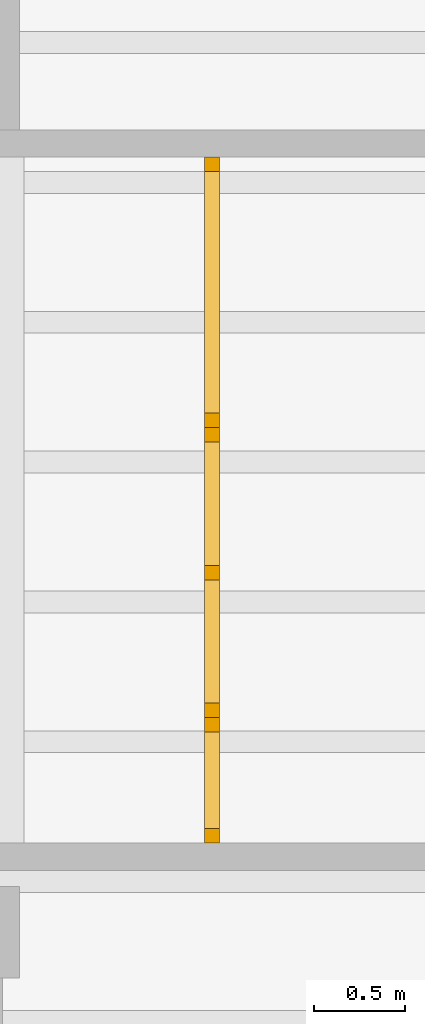
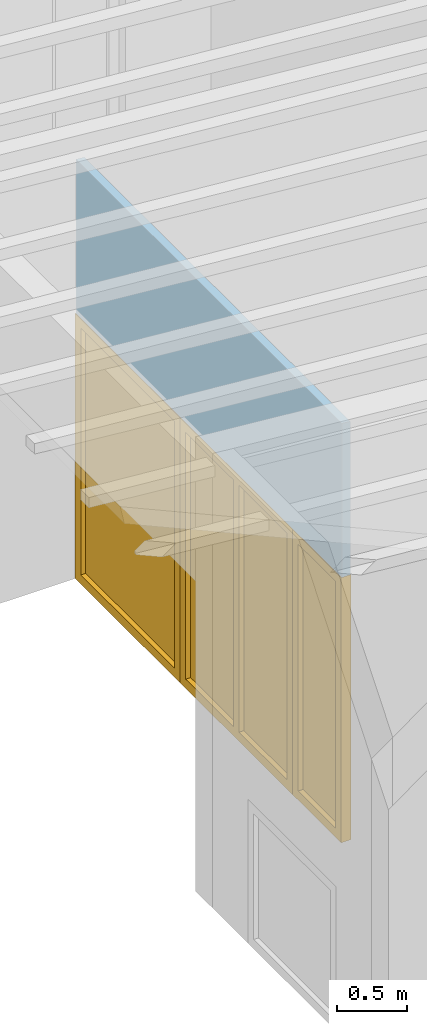
# One storey, part 8 of 13: 2 doors, 1 window, 3 openings, plus 1 element that does not belong to this part.
"""IFC2X3 building model written with IfcOpenShell, lengths in millimetres."""

from ifc_helpers import new_model, entity, si_unit, converted_unit, frame, frame_2d, origin, origin_with_axes, place, context, project, spatial, rectangle, extrude, clip, halfspace, faceted_brep, material, layer, layer_set, layer_usage, type_object, element, fill, save


model = new_model("IFC2X3")

# Units and contexts
model_context = context("Model", 3, precision=1e-05, world=origin())
plan_context = context("Plan", 3, precision=1e-05, world=origin())
ifc_project = project(units=[si_unit("LENGTHUNIT", "METRE", prefix="MILLI"), converted_unit("PLANEANGLEUNIT", "DEGREE", entity("IfcPlaneAngleMeasure", 0.0174532925199433), si_unit("PLANEANGLEUNIT", "RADIAN"), dimensions=[0, 0, 0, 0, 0, 0, 0]), si_unit("AREAUNIT", "SQUARE_METRE"), si_unit("VOLUMEUNIT", "CUBIC_METRE")], contexts=[model_context, plan_context])

# Building, storey
building_placement = place(None, origin())
building = spatial("IfcBuilding", under=ifc_project, at=building_placement, CompositionType="ELEMENT")
storey_placement = place(building_placement, frame((0.0, 0.0, 4770.0), z_axis=(0.0, 0.0, 1.0), x_axis=(1.0, 0.0, 0.0)))
storey = spatial("IfcBuildingStorey", under=building, at=storey_placement, Name="Geschoss", CompositionType="ELEMENT", Elevation=4770.0)

# Wall, openings, doors, window
ifc_material_1 = material(Name="glas")
ifc_layer = layer(ifc_material_1, 70.0)
ifc_layer_set = layer_set([ifc_layer])
ifc_layer_usage = layer_usage(ifc_layer_set, "AXIS2", "POSITIVE", 0.0)
wall_placement = place(storey_placement, frame((22458.3517822139, 1928.4375, 0.0), z_axis=(0.0, 0.0, 1.0), x_axis=(0.0, 1.0, 0.0)))
wall = element("IfcWallStandardCase", 1, at=wall_placement, inside=storey, material=ifc_layer_usage, context=model_context, shape_type="Clipping", body=[
    clip(extrude(rectangle(XDim=3780.0, YDim=70.0, at=frame_2d((1890.0, 35.0), x_axis=(1.0, 0.0))), origin_with_axes(), (0.0, 0.0, 1.0), 3635.62189784294), halfspace(frame((0.0, 0.0, 3629.49769139612), z_axis=(0.0, 0.0871557427476649, -0.996194698091745), x_axis=(1.0, 0.0, 0.0)), True)),
])
opening_1_placement = place(wall_placement, frame((0.0, 0.0, 0.0), z_axis=(0.0, 1.0, 0.0), x_axis=(0.0, 0.0, 1.0)))
opening_1 = element("IfcOpeningElement", 2, at=opening_1_placement, cuts=wall, ObjectType="Opening", context=model_context, shape_type="SweptSolid", body=[
    extrude(rectangle(XDim=2300.0, YDim=689.999999999996, at=frame_2d((1150.0, 344.999999999998), x_axis=(1.0, 0.0))), origin_with_axes(), (0.0, 0.0, 1.0), 70.0),
])
opening_2_placement = place(wall_placement, frame((2290.0, 0.0, 0.0), z_axis=(0.0, 1.0, 0.0), x_axis=(0.0, 0.0, 1.0)))
opening_2 = element("IfcOpeningElement", 3, at=opening_2_placement, cuts=wall, ObjectType="Opening", context=model_context, shape_type="SweptSolid", body=[
    extrude(rectangle(XDim=2300.0, YDim=1490.0, at=frame_2d((1150.0, 745.0), x_axis=(1.0, 0.0))), origin_with_axes(), (0.0, 0.0, 1.0), 70.0),
])
opening_3_placement = place(wall_placement, frame((689.999999999996, 0.0, 0.0), z_axis=(0.0, 1.0, 0.0), x_axis=(0.0, 0.0, 1.0)))
opening_3 = element("IfcOpeningElement", 4, at=opening_3_placement, cuts=wall, ObjectType="Opening", context=model_context, shape_type="SweptSolid", body=[
    extrude(rectangle(XDim=2300.0, YDim=1600.0, at=frame_2d((1150.0, 800.0), x_axis=(1.0, 0.0))), origin_with_axes(), (0.0, 0.0, 1.0), 70.0),
])
ifc_material_2 = material()
door_style_1 = type_object("IfcDoorStyle", Name="Verglasung 01", ConstructionType="NOTDEFINED", OperationType="USERDEFINED", ParameterTakesPrecedence=False, Sizeable=False)
door_1_placement = place(opening_1_placement, frame((0.0, 0.0, 0.0), z_axis=(1.0, 0.0, 0.0), x_axis=(0.0, 1.0, 0.0)))
door_1 = element("IfcDoor", 5, at=door_1_placement, inside=storey, type_object=door_style_1, material=ifc_material_2, Name="Verglasung 01", OverallHeight=2300.0, OverallWidth=690.0, context=model_context, shape_type="Brep", body=[
    faceted_brep([(80.0, 75.0000000000015, 0.0), (80.0, 75.0000000000015, 2300.0), (0.0, 75.0000000000015, 2300.0), (0.0, 75.0000000000015, 0.0), (0.0, -4.99999999999849, 0.0), (0.0, -4.99999999999849, 2300.0), (80.0, -4.99999999999849, 2300.0), (80.0, -4.99999999999849, 0.0), (0.0, 75.0000000000015, 0.0), (0.0, -4.99999999999849, 0.0), (80.0, -4.99999999999849, 0.0), (80.0, 75.0000000000015, 0.0), (0.0, 75.0000000000015, 2300.0), (0.0, -4.99999999999849, 2300.0), (0.0, -4.99999999999849, 0.0), (0.0, 75.0000000000015, 0.0), (80.0, 75.0000000000015, 2300.0), (80.0, -4.99999999999849, 2300.0), (0.0, -4.99999999999849, 2300.0), (0.0, 75.0000000000015, 2300.0), (80.0, 75.0000000000015, 0.0), (80.0, -4.99999999999849, 0.0), (80.0, -4.99999999999849, 2300.0), (80.0, 75.0000000000015, 2300.0)], [[[0, 1, 2, 3]], [[4, 5, 6, 7]], [[8, 9, 10, 11]], [[12, 13, 14, 15]], [[16, 17, 18, 19]], [[20, 21, 22, 23]]], orient=[[False], [False], [False], [False], [False], [False]]),
    faceted_brep([(609.999999999996, 75.0000000000015, 2300.0), (609.999999999996, 75.0000000000015, 0.0), (689.999999999996, 75.0000000000015, 0.0), (689.999999999996, 75.0000000000015, 2300.0), (689.999999999996, -4.99999999999854, 2300.0), (689.999999999996, -4.99999999999854, 0.0), (609.999999999996, -4.99999999999854, 0.0), (609.999999999996, -4.99999999999854, 2300.0), (689.999999999996, 75.0000000000015, 2300.0), (689.999999999996, -4.99999999999854, 2300.0), (609.999999999996, -4.99999999999854, 2300.0), (609.999999999996, 75.0000000000015, 2300.0), (689.999999999996, 75.0000000000015, 0.0), (689.999999999996, -4.99999999999854, 0.0), (689.999999999996, -4.99999999999854, 2300.0), (689.999999999996, 75.0000000000015, 2300.0), (609.999999999996, 75.0000000000015, 0.0), (609.999999999996, -4.99999999999854, 0.0), (689.999999999996, -4.99999999999854, 0.0), (689.999999999996, 75.0000000000015, 0.0), (609.999999999996, 75.0000000000015, 2300.0), (609.999999999996, -4.99999999999854, 2300.0), (609.999999999996, -4.99999999999854, 0.0), (609.999999999996, 75.0000000000015, 0.0)], [[[0, 1, 2, 3]], [[4, 5, 6, 7]], [[8, 9, 10, 11]], [[12, 13, 14, 15]], [[16, 17, 18, 19]], [[20, 21, 22, 23]]], orient=[[False], [False], [False], [False], [False], [False]]),
    faceted_brep([(80.0, 75.0000000000015, 2220.0), (609.999999999996, 75.0000000000015, 2220.0), (609.999999999996, 75.0000000000015, 2300.0), (80.0, 75.0000000000015, 2300.0), (80.0, -4.99999999999851, 2300.0), (609.999999999996, -4.99999999999855, 2300.0), (609.999999999996, -4.99999999999855, 2220.0), (80.0, -4.99999999999851, 2220.0), (80.0, 75.0000000000015, 2300.0), (80.0, -4.99999999999851, 2300.0), (80.0, -4.99999999999851, 2220.0), (80.0, 75.0000000000015, 2220.0), (609.999999999996, 75.0000000000015, 2300.0), (609.999999999996, -4.99999999999855, 2300.0), (80.0, -4.99999999999851, 2300.0), (80.0, 75.0000000000015, 2300.0), (609.999999999996, 75.0000000000015, 2220.0), (609.999999999996, -4.99999999999855, 2220.0), (609.999999999996, -4.99999999999855, 2300.0), (609.999999999996, 75.0000000000015, 2300.0), (80.0, 75.0000000000015, 2220.0), (80.0, -4.99999999999851, 2220.0), (609.999999999996, -4.99999999999855, 2220.0), (609.999999999996, 75.0000000000015, 2220.0)], [[[0, 1, 2, 3]], [[4, 5, 6, 7]], [[8, 9, 10, 11]], [[12, 13, 14, 15]], [[16, 17, 18, 19]], [[20, 21, 22, 23]]], orient=[[False], [False], [False], [False], [False], [False]]),
    faceted_brep([(609.999999999996, 75.0000000000015, 80.0), (80.0, 75.0000000000015, 80.0), (80.0, 75.0000000000015, 0.0), (609.999999999996, 75.0000000000015, 0.0), (609.999999999996, -4.99999999999855, 0.0), (80.0, -4.99999999999851, 0.0), (80.0, -4.99999999999851, 80.0), (609.999999999996, -4.99999999999855, 80.0), (609.999999999996, 75.0000000000015, 0.0), (609.999999999996, -4.99999999999855, 0.0), (609.999999999996, -4.99999999999855, 80.0), (609.999999999996, 75.0000000000015, 80.0), (80.0, 75.0000000000015, 0.0), (80.0, -4.99999999999851, 0.0), (609.999999999996, -4.99999999999855, 0.0), (609.999999999996, 75.0000000000015, 0.0), (80.0, 75.0000000000015, 80.0), (80.0, -4.99999999999851, 80.0), (80.0, -4.99999999999851, 0.0), (80.0, 75.0000000000015, 0.0), (609.999999999996, 75.0000000000015, 80.0), (609.999999999996, -4.99999999999855, 80.0), (80.0, -4.99999999999851, 80.0), (80.0, 75.0000000000015, 80.0)], [[[0, 1, 2, 3]], [[4, 5, 6, 7]], [[8, 9, 10, 11]], [[12, 13, 14, 15]], [[16, 17, 18, 19]], [[20, 21, 22, 23]]], orient=[[False], [False], [False], [False], [False], [False]]),
    faceted_brep([(80.0, 35.0000000000015, 80.0), (609.999999999996, 35.0000000000015, 80.0), (609.999999999996, 35.0000000000015, 2220.0), (80.0, 35.0000000000015, 2220.0), (80.0, 34.0000000000015, 80.0), (80.0, 34.0000000000015, 2220.0), (609.999999999996, 34.0000000000015, 2220.0), (609.999999999996, 34.0000000000015, 80.0), (80.0, 35.0000000000015, 80.0), (80.0, 34.0000000000015, 80.0), (609.999999999996, 34.0000000000015, 80.0), (609.999999999996, 35.0000000000015, 80.0), (609.999999999996, 35.0000000000015, 80.0), (609.999999999996, 34.0000000000015, 80.0), (609.999999999996, 34.0000000000015, 2220.0), (609.999999999996, 35.0000000000015, 2220.0), (609.999999999996, 35.0000000000015, 2220.0), (609.999999999996, 34.0000000000015, 2220.0), (80.0, 34.0000000000015, 2220.0), (80.0, 35.0000000000015, 2220.0), (80.0, 35.0000000000015, 2220.0), (80.0, 34.0000000000015, 2220.0), (80.0, 34.0000000000015, 80.0), (80.0, 35.0000000000015, 80.0)], [[[0, 1, 2, 3]], [[4, 5, 6, 7]], [[8, 9, 10, 11]], [[12, 13, 14, 15]], [[16, 17, 18, 19]], [[20, 21, 22, 23]]], orient=[[False], [False], [False], [False], [False], [False]]),
])
fill(opening_1, door_1)
ifc_material_3 = material()
door_style_2 = type_object("IfcDoorStyle", Name="m", ConstructionType="NOTDEFINED", OperationType="USERDEFINED", ParameterTakesPrecedence=False, Sizeable=False)
door_2_placement = place(opening_2_placement, frame((0.0, 0.0, 0.0), z_axis=(1.0, 0.0, 0.0), x_axis=(0.0, 1.0, 0.0)))
door_2 = element("IfcDoor", 6, at=door_2_placement, inside=storey, type_object=door_style_2, material=ifc_material_3, Name="m", OverallHeight=2300.0, OverallWidth=1490.0, context=model_context, shape_type="Brep", body=[
    faceted_brep([(79.9999999999998, 75.0000000000016, 0.0), (79.9999999999998, 75.0000000000016, 2300.0), (-2.27373675443232e-13, 75.0000000000016, 2300.0), (-2.27373675443232e-13, 75.0000000000016, 0.0), (-2.27373675443232e-13, -4.99999999999845, 0.0), (-2.27373675443232e-13, -4.99999999999845, 2300.0), (79.9999999999998, -4.99999999999845, 2300.0), (79.9999999999998, -4.99999999999845, 0.0), (-2.27373675443232e-13, 75.0000000000016, 0.0), (-2.27373675443232e-13, -4.99999999999845, 0.0), (79.9999999999998, -4.99999999999845, 0.0), (79.9999999999998, 75.0000000000016, 0.0), (-2.27373675443232e-13, 75.0000000000016, 2300.0), (-2.27373675443232e-13, -4.99999999999845, 2300.0), (-2.27373675443232e-13, -4.99999999999845, 0.0), (-2.27373675443232e-13, 75.0000000000016, 0.0), (79.9999999999998, 75.0000000000016, 2300.0), (79.9999999999998, -4.99999999999845, 2300.0), (-2.27373675443232e-13, -4.99999999999845, 2300.0), (-2.27373675443232e-13, 75.0000000000016, 2300.0), (79.9999999999998, 75.0000000000016, 0.0), (79.9999999999998, -4.99999999999845, 0.0), (79.9999999999998, -4.99999999999845, 2300.0), (79.9999999999998, 75.0000000000016, 2300.0)], [[[0, 1, 2, 3]], [[4, 5, 6, 7]], [[8, 9, 10, 11]], [[12, 13, 14, 15]], [[16, 17, 18, 19]], [[20, 21, 22, 23]]], orient=[[False], [False], [False], [False], [False], [False]]),
    faceted_brep([(1410.0, 75.0000000000015, 2300.0), (1410.0, 75.0000000000015, 0.0), (1490.0, 75.0000000000015, 0.0), (1490.0, 75.0000000000015, 2300.0), (1490.0, -4.99999999999854, 2300.0), (1490.0, -4.99999999999854, 0.0), (1410.0, -4.99999999999854, 0.0), (1410.0, -4.99999999999854, 2300.0), (1490.0, 75.0000000000015, 2300.0), (1490.0, -4.99999999999854, 2300.0), (1410.0, -4.99999999999854, 2300.0), (1410.0, 75.0000000000015, 2300.0), (1490.0, 75.0000000000015, 0.0), (1490.0, -4.99999999999854, 0.0), (1490.0, -4.99999999999854, 2300.0), (1490.0, 75.0000000000015, 2300.0), (1410.0, 75.0000000000015, 0.0), (1410.0, -4.99999999999854, 0.0), (1490.0, -4.99999999999854, 0.0), (1490.0, 75.0000000000015, 0.0), (1410.0, 75.0000000000015, 2300.0), (1410.0, -4.99999999999854, 2300.0), (1410.0, -4.99999999999854, 0.0), (1410.0, 75.0000000000015, 0.0)], [[[0, 1, 2, 3]], [[4, 5, 6, 7]], [[8, 9, 10, 11]], [[12, 13, 14, 15]], [[16, 17, 18, 19]], [[20, 21, 22, 23]]], orient=[[False], [False], [False], [False], [False], [False]]),
    faceted_brep([(79.9999999999998, 75.0000000000015, 2220.0), (1410.0, 75.0000000000015, 2220.0), (1410.0, 75.0000000000015, 2300.0), (79.9999999999998, 75.0000000000015, 2300.0), (79.9999999999998, -4.99999999999847, 2300.0), (1410.0, -4.99999999999855, 2300.0), (1410.0, -4.99999999999855, 2220.0), (79.9999999999998, -4.99999999999847, 2220.0), (79.9999999999998, 75.0000000000015, 2300.0), (79.9999999999998, -4.99999999999847, 2300.0), (79.9999999999998, -4.99999999999847, 2220.0), (79.9999999999998, 75.0000000000015, 2220.0), (1410.0, 75.0000000000015, 2300.0), (1410.0, -4.99999999999855, 2300.0), (79.9999999999998, -4.99999999999847, 2300.0), (79.9999999999998, 75.0000000000015, 2300.0), (1410.0, 75.0000000000015, 2220.0), (1410.0, -4.99999999999855, 2220.0), (1410.0, -4.99999999999855, 2300.0), (1410.0, 75.0000000000015, 2300.0), (79.9999999999998, 75.0000000000015, 2220.0), (79.9999999999998, -4.99999999999847, 2220.0), (1410.0, -4.99999999999855, 2220.0), (1410.0, 75.0000000000015, 2220.0)], [[[0, 1, 2, 3]], [[4, 5, 6, 7]], [[8, 9, 10, 11]], [[12, 13, 14, 15]], [[16, 17, 18, 19]], [[20, 21, 22, 23]]], orient=[[False], [False], [False], [False], [False], [False]]),
    faceted_brep([(1410.0, 75.0000000000015, 80.0), (79.9999999999998, 75.0000000000015, 80.0), (79.9999999999998, 75.0000000000015, 0.0), (1410.0, 75.0000000000015, 0.0), (1410.0, -4.99999999999855, 0.0), (79.9999999999998, -4.99999999999847, 0.0), (79.9999999999998, -4.99999999999847, 80.0), (1410.0, -4.99999999999855, 80.0), (1410.0, 75.0000000000015, 0.0), (1410.0, -4.99999999999855, 0.0), (1410.0, -4.99999999999855, 80.0), (1410.0, 75.0000000000015, 80.0), (79.9999999999998, 75.0000000000015, 0.0), (79.9999999999998, -4.99999999999847, 0.0), (1410.0, -4.99999999999855, 0.0), (1410.0, 75.0000000000015, 0.0), (79.9999999999998, 75.0000000000015, 80.0), (79.9999999999998, -4.99999999999847, 80.0), (79.9999999999998, -4.99999999999847, 0.0), (79.9999999999998, 75.0000000000015, 0.0), (1410.0, 75.0000000000015, 80.0), (1410.0, -4.99999999999855, 80.0), (79.9999999999998, -4.99999999999847, 80.0), (79.9999999999998, 75.0000000000015, 80.0)], [[[0, 1, 2, 3]], [[4, 5, 6, 7]], [[8, 9, 10, 11]], [[12, 13, 14, 15]], [[16, 17, 18, 19]], [[20, 21, 22, 23]]], orient=[[False], [False], [False], [False], [False], [False]]),
    faceted_brep([(79.9999999999998, 35.0000000000015, 80.0), (1410.0, 35.0000000000015, 80.0), (1410.0, 35.0000000000015, 2220.0), (79.9999999999998, 35.0000000000015, 2220.0), (79.9999999999998, 34.0000000000015, 80.0), (79.9999999999998, 34.0000000000015, 2220.0), (1410.0, 34.0000000000015, 2220.0), (1410.0, 34.0000000000015, 80.0), (79.9999999999998, 35.0000000000015, 80.0), (79.9999999999998, 34.0000000000015, 80.0), (1410.0, 34.0000000000015, 80.0), (1410.0, 35.0000000000015, 80.0), (1410.0, 35.0000000000015, 80.0), (1410.0, 34.0000000000015, 80.0), (1410.0, 34.0000000000015, 2220.0), (1410.0, 35.0000000000015, 2220.0), (1410.0, 35.0000000000015, 2220.0), (1410.0, 34.0000000000015, 2220.0), (79.9999999999998, 34.0000000000015, 2220.0), (79.9999999999998, 35.0000000000015, 2220.0), (79.9999999999998, 35.0000000000015, 2220.0), (79.9999999999998, 34.0000000000015, 2220.0), (79.9999999999998, 34.0000000000015, 80.0), (79.9999999999998, 35.0000000000015, 80.0)], [[[0, 1, 2, 3]], [[4, 5, 6, 7]], [[8, 9, 10, 11]], [[12, 13, 14, 15]], [[16, 17, 18, 19]], [[20, 21, 22, 23]]], orient=[[False], [False], [False], [False], [False], [False]]),
])
fill(opening_2, door_2)
ifc_material_4 = material()
window_placement = place(opening_3_placement, frame((0.0, 0.0, 0.0), z_axis=(1.0, 0.0, 0.0), x_axis=(0.0, 1.0, 0.0)))
window = element("IfcWindow", 7, at=window_placement, inside=storey, material=ifc_material_4, Name="m", OverallHeight=2300.0, OverallWidth=1600.0, context=model_context, shape_type="Brep", body=[
    faceted_brep([(80.0000000000005, 75.0000000000016, 0.0), (80.0000000000005, 75.0000000000016, 2300.0), (4.54747350886464e-13, 75.0000000000016, 2300.0), (4.54747350886464e-13, 75.0000000000016, 0.0), (4.54747350886464e-13, -4.99999999999844, 0.0), (4.54747350886464e-13, -4.99999999999844, 2300.0), (80.0000000000005, -4.99999999999844, 2300.0), (80.0000000000005, -4.99999999999844, 0.0), (4.54747350886464e-13, 75.0000000000016, 0.0), (4.54747350886464e-13, -4.99999999999844, 0.0), (80.0000000000005, -4.99999999999844, 0.0), (80.0000000000005, 75.0000000000016, 0.0), (4.54747350886464e-13, 75.0000000000016, 2300.0), (4.54747350886464e-13, -4.99999999999844, 2300.0), (4.54747350886464e-13, -4.99999999999844, 0.0), (4.54747350886464e-13, 75.0000000000016, 0.0), (80.0000000000005, 75.0000000000016, 2300.0), (80.0000000000005, -4.99999999999844, 2300.0), (4.54747350886464e-13, -4.99999999999844, 2300.0), (4.54747350886464e-13, 75.0000000000016, 2300.0), (80.0000000000005, 75.0000000000016, 0.0), (80.0000000000005, -4.99999999999844, 0.0), (80.0000000000005, -4.99999999999844, 2300.0), (80.0000000000005, 75.0000000000016, 2300.0)], [[[0, 1, 2, 3]], [[4, 5, 6, 7]], [[8, 9, 10, 11]], [[12, 13, 14, 15]], [[16, 17, 18, 19]], [[20, 21, 22, 23]]], orient=[[False], [False], [False], [False], [False], [False]]),
    faceted_brep([(1520.0, 75.0000000000015, 2300.0), (1520.0, 75.0000000000015, 0.0), (1600.0, 75.0000000000015, 0.0), (1600.0, 75.0000000000015, 2300.0), (1600.0, -4.99999999999854, 2300.0), (1600.0, -4.99999999999854, 0.0), (1520.0, -4.99999999999854, 0.0), (1520.0, -4.99999999999854, 2300.0), (1600.0, 75.0000000000015, 2300.0), (1600.0, -4.99999999999854, 2300.0), (1520.0, -4.99999999999854, 2300.0), (1520.0, 75.0000000000015, 2300.0), (1600.0, 75.0000000000015, 0.0), (1600.0, -4.99999999999854, 0.0), (1600.0, -4.99999999999854, 2300.0), (1600.0, 75.0000000000015, 2300.0), (1520.0, 75.0000000000015, 0.0), (1520.0, -4.99999999999854, 0.0), (1600.0, -4.99999999999854, 0.0), (1600.0, 75.0000000000015, 0.0), (1520.0, 75.0000000000015, 2300.0), (1520.0, -4.99999999999854, 2300.0), (1520.0, -4.99999999999854, 0.0), (1520.0, 75.0000000000015, 0.0)], [[[0, 1, 2, 3]], [[4, 5, 6, 7]], [[8, 9, 10, 11]], [[12, 13, 14, 15]], [[16, 17, 18, 19]], [[20, 21, 22, 23]]], orient=[[False], [False], [False], [False], [False], [False]]),
    faceted_brep([(80.0000000000005, 75.0000000000015, 2220.0), (1520.0, 75.0000000000015, 2220.0), (1520.0, 75.0000000000015, 2300.0), (80.0000000000005, 75.0000000000015, 2300.0), (80.0000000000005, -4.99999999999845, 2300.0), (1520.0, -4.99999999999855, 2300.0), (1520.0, -4.99999999999855, 2220.0), (80.0000000000005, -4.99999999999845, 2220.0), (80.0000000000005, 75.0000000000015, 2300.0), (80.0000000000005, -4.99999999999845, 2300.0), (80.0000000000005, -4.99999999999845, 2220.0), (80.0000000000005, 75.0000000000015, 2220.0), (1520.0, 75.0000000000015, 2300.0), (1520.0, -4.99999999999855, 2300.0), (80.0000000000005, -4.99999999999845, 2300.0), (80.0000000000005, 75.0000000000015, 2300.0), (1520.0, 75.0000000000015, 2220.0), (1520.0, -4.99999999999855, 2220.0), (1520.0, -4.99999999999855, 2300.0), (1520.0, 75.0000000000015, 2300.0), (80.0000000000005, 75.0000000000015, 2220.0), (80.0000000000005, -4.99999999999845, 2220.0), (1520.0, -4.99999999999855, 2220.0), (1520.0, 75.0000000000015, 2220.0)], [[[0, 1, 2, 3]], [[4, 5, 6, 7]], [[8, 9, 10, 11]], [[12, 13, 14, 15]], [[16, 17, 18, 19]], [[20, 21, 22, 23]]], orient=[[False], [False], [False], [False], [False], [False]]),
    faceted_brep([(1520.0, 75.0000000000015, 80.0), (80.0000000000005, 75.0000000000015, 80.0), (80.0000000000005, 75.0000000000015, 0.0), (1520.0, 75.0000000000015, 0.0), (1520.0, -4.99999999999855, 0.0), (80.0000000000005, -4.99999999999845, 0.0), (80.0000000000005, -4.99999999999845, 80.0), (1520.0, -4.99999999999855, 80.0), (1520.0, 75.0000000000015, 0.0), (1520.0, -4.99999999999855, 0.0), (1520.0, -4.99999999999855, 80.0), (1520.0, 75.0000000000015, 80.0), (80.0000000000005, 75.0000000000015, 0.0), (80.0000000000005, -4.99999999999845, 0.0), (1520.0, -4.99999999999855, 0.0), (1520.0, 75.0000000000015, 0.0), (80.0000000000005, 75.0000000000015, 80.0), (80.0000000000005, -4.99999999999845, 80.0), (80.0000000000005, -4.99999999999845, 0.0), (80.0000000000005, 75.0000000000015, 0.0), (1520.0, 75.0000000000015, 80.0), (1520.0, -4.99999999999855, 80.0), (80.0000000000005, -4.99999999999845, 80.0), (80.0000000000005, 75.0000000000015, 80.0)], [[[0, 1, 2, 3]], [[4, 5, 6, 7]], [[8, 9, 10, 11]], [[12, 13, 14, 15]], [[16, 17, 18, 19]], [[20, 21, 22, 23]]], orient=[[False], [False], [False], [False], [False], [False]]),
    faceted_brep([(840.0, 75.0000000000015, 80.0), (840.0, 75.0000000000015, 2220.0), (760.0, 75.0000000000015, 2220.0), (760.0, 75.0000000000015, 80.0), (760.0, -4.99999999999849, 80.0), (760.0, -4.99999999999849, 2220.0), (840.0, -4.99999999999851, 2220.0), (840.0, -4.99999999999851, 80.0), (760.0, 75.0000000000015, 80.0), (760.0, -4.99999999999849, 80.0), (840.0, -4.99999999999851, 80.0), (840.0, 75.0000000000015, 80.0), (760.0, 75.0000000000015, 2220.0), (760.0, -4.99999999999849, 2220.0), (760.0, -4.99999999999849, 80.0), (760.0, 75.0000000000015, 80.0), (840.0, 75.0000000000015, 2220.0), (840.0, -4.99999999999851, 2220.0), (760.0, -4.99999999999849, 2220.0), (760.0, 75.0000000000015, 2220.0), (840.0, 75.0000000000015, 80.0), (840.0, -4.99999999999851, 80.0), (840.0, -4.99999999999851, 2220.0), (840.0, 75.0000000000015, 2220.0)], [[[0, 1, 2, 3]], [[4, 5, 6, 7]], [[8, 9, 10, 11]], [[12, 13, 14, 15]], [[16, 17, 18, 19]], [[20, 21, 22, 23]]], orient=[[False], [False], [False], [False], [False], [False]]),
    faceted_brep([(1520.0, 35.0000000000015, 2220.0), (840.0, 35.0000000000015, 2220.0), (840.0, 35.0000000000015, 80.0), (1520.0, 35.0000000000015, 80.0), (1520.0, 34.0000000000015, 2220.0), (1520.0, 34.0000000000015, 80.0), (840.0, 34.0000000000015, 80.0), (840.0, 34.0000000000015, 2220.0), (1520.0, 35.0000000000015, 2220.0), (1520.0, 34.0000000000015, 2220.0), (840.0, 34.0000000000015, 2220.0), (840.0, 35.0000000000015, 2220.0), (840.0, 35.0000000000015, 2220.0), (840.0, 34.0000000000015, 2220.0), (840.0, 34.0000000000015, 80.0), (840.0, 35.0000000000015, 80.0), (840.0, 35.0000000000015, 80.0), (840.0, 34.0000000000015, 80.0), (1520.0, 34.0000000000015, 80.0), (1520.0, 35.0000000000015, 80.0), (1520.0, 35.0000000000015, 80.0), (1520.0, 34.0000000000015, 80.0), (1520.0, 34.0000000000015, 2220.0), (1520.0, 35.0000000000015, 2220.0)], [[[0, 1, 2, 3]], [[4, 5, 6, 7]], [[8, 9, 10, 11]], [[12, 13, 14, 15]], [[16, 17, 18, 19]], [[20, 21, 22, 23]]], orient=[[False], [False], [False], [False], [False], [False]]),
    faceted_brep([(80.0000000000005, 35.0000000000015, 80.0), (760.0, 35.0000000000015, 80.0), (760.0, 35.0000000000015, 2220.0), (80.0000000000005, 35.0000000000015, 2220.0), (80.0000000000005, 34.0000000000015, 80.0), (80.0000000000005, 34.0000000000015, 2220.0), (760.0, 34.0000000000015, 2220.0), (760.0, 34.0000000000015, 80.0), (80.0000000000005, 35.0000000000015, 80.0), (80.0000000000005, 34.0000000000015, 80.0), (760.0, 34.0000000000015, 80.0), (760.0, 35.0000000000015, 80.0), (760.0, 35.0000000000015, 80.0), (760.0, 34.0000000000015, 80.0), (760.0, 34.0000000000015, 2220.0), (760.0, 35.0000000000015, 2220.0), (760.0, 35.0000000000015, 2220.0), (760.0, 34.0000000000015, 2220.0), (80.0000000000005, 34.0000000000015, 2220.0), (80.0000000000005, 35.0000000000015, 2220.0), (80.0000000000005, 35.0000000000015, 2220.0), (80.0000000000005, 34.0000000000015, 2220.0), (80.0000000000005, 34.0000000000015, 80.0), (80.0000000000005, 35.0000000000015, 80.0)], [[[0, 1, 2, 3]], [[4, 5, 6, 7]], [[8, 9, 10, 11]], [[12, 13, 14, 15]], [[16, 17, 18, 19]], [[20, 21, 22, 23]]], orient=[[False], [False], [False], [False], [False], [False]]),
])
fill(opening_3, window)

save(model, "model.ifc")
